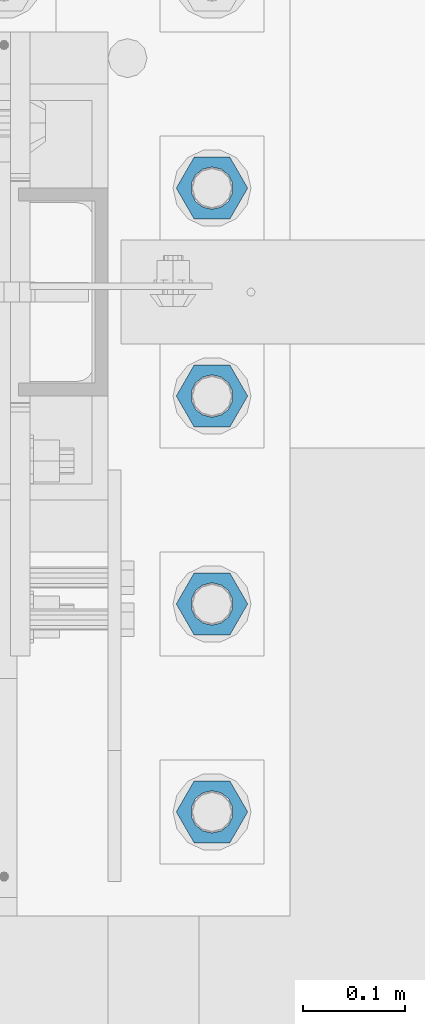
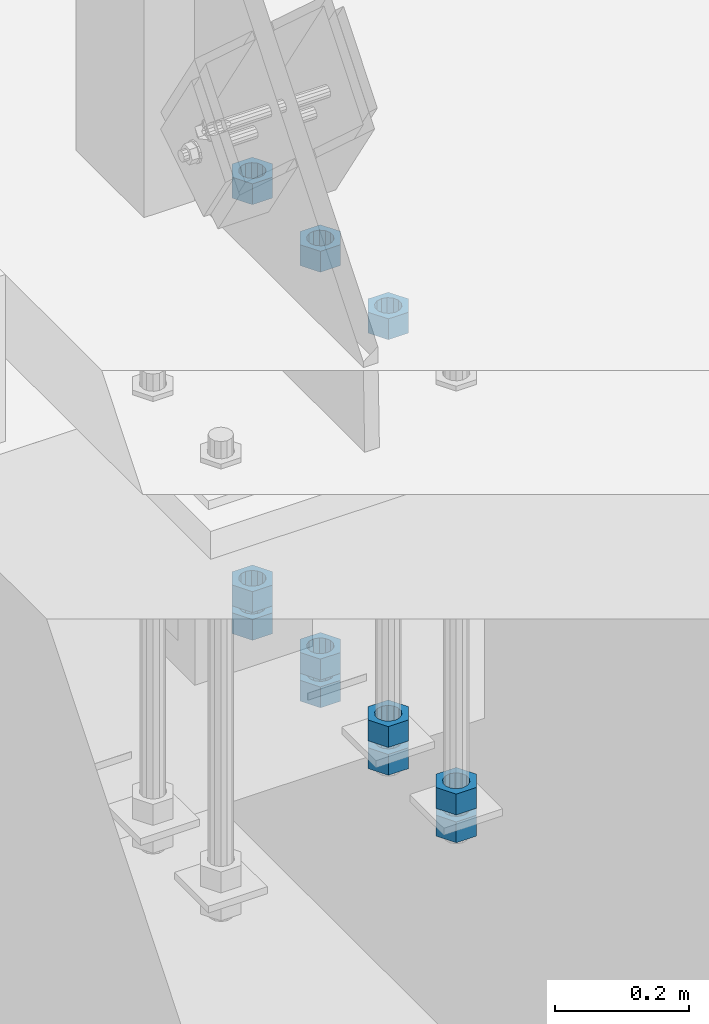
# One storey, part 989 of 1763: 11 columns, 1 element without a shape of its own.
"""IFC2X3 building model written with IfcOpenShell, lengths in millimetres."""

from ifc_helpers import new_model, si_unit, frame, origin_with_axes, place, context, subcontext, project, spatial, faceted_brep, material, type_object, element, aggregate, save


model = new_model("IFC2X3")

# Units and contexts
model_context = context("Model", 3, precision=1e-05, world=origin_with_axes())
body_context = subcontext(model_context, "Body", "Model", "MODEL_VIEW")
ifc_project = project(units=[si_unit("LENGTHUNIT", "METRE", prefix="MILLI"), si_unit("AREAUNIT", "SQUARE_METRE"), si_unit("VOLUMEUNIT", "CUBIC_METRE"), si_unit("MASSUNIT", "GRAM", prefix="KILO"), si_unit("TIMEUNIT", "SECOND"), si_unit("PLANEANGLEUNIT", "RADIAN"), si_unit("SOLIDANGLEUNIT", "STERADIAN"), si_unit("THERMODYNAMICTEMPERATUREUNIT", "DEGREE_CELSIUS"), si_unit("LUMINOUSINTENSITYUNIT", "LUMEN")], contexts=[model_context])

# Site, building, storey
site_placement = place(None, origin_with_axes())
site = spatial("IfcSite", under=ifc_project, at=site_placement, CompositionType="ELEMENT")
building_placement = place(site_placement, origin_with_axes())
building = spatial("IfcBuilding", under=site, at=building_placement, Name="Undefined", CompositionType="ELEMENT")
storey_placement = place(building_placement, origin_with_axes())
storey = spatial("IfcBuildingStorey", under=building, at=storey_placement, Name="Undefined", CompositionType="ELEMENT", Elevation=0.0)

# Assembly, columns
assembly_placement = place(storey_placement, origin_with_axes())
assembly = element("IfcElementAssembly", 1, at=assembly_placement, inside=storey, Name="TEMPLATE", AssemblyPlace="NOTDEFINED", PredefinedType="RIGID_FRAME")
ifc_material = material(Name="STEEL/A563")
column_type = type_object("IfcColumnType", Name="1-1/2_HEAVY_HEX_NUT", PredefinedType="NOTDEFINED")
column_1_placement = place(assembly_placement, frame((-87172.2372736984, 8026.40000000001, 4445.00000000001), z_axis=(0.0, 1.0, 0.0), x_axis=(0.0, 0.0, -1.0)))
column_1 = element("IfcColumn", 2, at=column_1_placement, type_object=column_type, material=ifc_material, Name="NUT", ObjectType="1-1/2_HEAVY_HEX_NUT", context=body_context, shape_type="Brep", body=[
    faceted_brep([(0.0, -34.9199981689453, 0.0), (0.0, -17.4599990844727, -30.25), (38.1000000000004, -17.4599990844727, -30.25), (38.1000000000004, -34.9199981689453, 0.0), (0.0, 17.4599990844727, -30.25), (38.1000000000004, 17.4599990844727, -30.25), (0.0, 34.9199981689453, 0.0), (38.1000000000004, 34.9199981689453, 0.0), (0.0, 17.4599990844727, 30.25), (38.1000000000004, 17.4599990844727, 30.25), (0.0, -17.4599990844727, 30.25), (38.1000000000004, -17.4599990844727, 30.25), (0.0, 0.0, 20.6399993896484), (0.0, 8.95536011056538, 18.5959968835978), (38.1000000000004, 8.95536011056538, 18.5959968835978), (38.1000000000004, 0.0, 20.6399993896484), (0.0, 16.1370013209453, 12.8688291298167), (38.1000000000004, 16.1370013209453, 12.8688291298167), (0.0, 20.1225115123816, 4.59283194104137), (38.1000000000004, 20.1225115123816, 4.59283194104137), (0.0, 20.1225115123816, -4.59283194104319), (38.1000000000004, 20.1225115123816, -4.59283194104319), (0.0, 16.1370013209453, -12.8688291298167), (38.1000000000004, 16.1370013209453, -12.8688291298167), (0.0, 8.95536011056538, -18.5959968835978), (38.1000000000004, 8.95536011056538, -18.5959968835978), (0.0, 0.0, -20.6399993896484), (38.1000000000004, 0.0, -20.6399993896484), (0.0, -8.95536011056538, -18.5959968835978), (38.1000000000004, -8.95536011056538, -18.5959968835978), (0.0, -16.1370013209453, -12.8688291298167), (38.1000000000004, -16.1370013209453, -12.8688291298167), (0.0, -20.1225115123816, -4.59283194104137), (38.1000000000004, -20.1225115123816, -4.59283194104137), (0.0, -20.1225115123816, 4.59283194104319), (38.1000000000004, -20.1225115123816, 4.59283194104319), (0.0, -16.1370013209453, 12.8688291298167), (38.1000000000004, -16.1370013209453, 12.8688291298167), (0.0, -8.95536011056538, 18.5959968835978), (38.1000000000004, -8.95536011056538, 18.5959968835978)], [[[0, 1, 2, 3]], [[1, 4, 5, 2]], [[4, 6, 7, 5]], [[6, 8, 9, 7]], [[8, 10, 11, 9]], [[10, 0, 3, 11]], [[12, 13, 14, 15]], [[13, 16, 17, 14]], [[16, 18, 19, 17]], [[18, 20, 21, 19]], [[20, 22, 23, 21]], [[22, 24, 25, 23]], [[24, 26, 27, 25]], [[26, 28, 29, 27]], [[28, 30, 31, 29]], [[30, 32, 33, 31]], [[32, 34, 35, 33]], [[34, 36, 37, 35]], [[36, 38, 39, 37]], [[38, 12, 15, 39]], [[5, 7, 9, 11, 3, 2], [17, 19, 21, 23, 25, 27, 29, 31, 33, 35, 37, 39, 15, 14]], [[10, 8, 6, 4, 1, 0], [38, 36, 34, 32, 30, 28, 26, 24, 22, 20, 18, 16, 13, 12]]]),
])
column_2_placement = place(assembly_placement, frame((-87172.2372736984, 8026.40000000001, 4394.20000000001), z_axis=(0.0, 1.0, 0.0), x_axis=(0.0, 0.0, -1.0)))
column_2 = element("IfcColumn", 3, at=column_2_placement, type_object=column_type, material=ifc_material, Name="NUT", ObjectType="1-1/2_HEAVY_HEX_NUT", context=body_context, shape_type="Brep", body=[
    faceted_brep([(0.0, -34.9199981689453, 0.0), (0.0, -17.4599990844727, -30.25), (38.1000000000004, -17.4599990844727, -30.25), (38.1000000000004, -34.9199981689453, 0.0), (0.0, 17.4599990844727, -30.25), (38.1000000000004, 17.4599990844727, -30.25), (0.0, 34.9199981689453, 0.0), (38.1000000000004, 34.9199981689453, 0.0), (0.0, 17.4599990844727, 30.25), (38.1000000000004, 17.4599990844727, 30.25), (0.0, -17.4599990844727, 30.25), (38.1000000000004, -17.4599990844727, 30.25), (0.0, 0.0, 20.6399993896484), (0.0, 8.95536011056538, 18.5959968835978), (38.1000000000004, 8.95536011056538, 18.5959968835978), (38.1000000000004, 0.0, 20.6399993896484), (0.0, 16.1370013209453, 12.8688291298167), (38.1000000000004, 16.1370013209453, 12.8688291298167), (0.0, 20.1225115123816, 4.59283194104137), (38.1000000000004, 20.1225115123816, 4.59283194104137), (0.0, 20.1225115123816, -4.59283194104319), (38.1000000000004, 20.1225115123816, -4.59283194104319), (0.0, 16.1370013209453, -12.8688291298167), (38.1000000000004, 16.1370013209453, -12.8688291298167), (0.0, 8.95536011056538, -18.5959968835978), (38.1000000000004, 8.95536011056538, -18.5959968835978), (0.0, 0.0, -20.6399993896484), (38.1000000000004, 0.0, -20.6399993896484), (0.0, -8.95536011056538, -18.5959968835978), (38.1000000000004, -8.95536011056538, -18.5959968835978), (0.0, -16.1370013209453, -12.8688291298167), (38.1000000000004, -16.1370013209453, -12.8688291298167), (0.0, -20.1225115123816, -4.59283194104137), (38.1000000000004, -20.1225115123816, -4.59283194104137), (0.0, -20.1225115123816, 4.59283194104319), (38.1000000000004, -20.1225115123816, 4.59283194104319), (0.0, -16.1370013209453, 12.8688291298167), (38.1000000000004, -16.1370013209453, 12.8688291298167), (0.0, -8.95536011056538, 18.5959968835978), (38.1000000000004, -8.95536011056538, 18.5959968835978)], [[[0, 1, 2, 3]], [[1, 4, 5, 2]], [[4, 6, 7, 5]], [[6, 8, 9, 7]], [[8, 10, 11, 9]], [[10, 0, 3, 11]], [[12, 13, 14, 15]], [[13, 16, 17, 14]], [[16, 18, 19, 17]], [[18, 20, 21, 19]], [[20, 22, 23, 21]], [[22, 24, 25, 23]], [[24, 26, 27, 25]], [[26, 28, 29, 27]], [[28, 30, 31, 29]], [[30, 32, 33, 31]], [[32, 34, 35, 33]], [[34, 36, 37, 35]], [[36, 38, 39, 37]], [[38, 12, 15, 39]], [[5, 7, 9, 11, 3, 2], [17, 19, 21, 23, 25, 27, 29, 31, 33, 35, 37, 39, 15, 14]], [[10, 8, 6, 4, 1, 0], [38, 36, 34, 32, 30, 28, 26, 24, 22, 20, 18, 16, 13, 12]]]),
])
column_3_placement = place(assembly_placement, frame((-87172.2372736984, 8229.60000000001, 5189.53750000001), z_axis=(0.0, 1.0, 0.0), x_axis=(0.0, 0.0, -1.0)))
column_3 = element("IfcColumn", 4, at=column_3_placement, type_object=column_type, material=ifc_material, Name="NUT", ObjectType="1-1/2_HEAVY_HEX_NUT", context=body_context, shape_type="Brep", body=[
    faceted_brep([(0.0, -34.9199981689453, 0.0), (0.0, -17.4599990844727, -30.25), (38.1000000000004, -17.4599990844727, -30.25), (38.1000000000004, -34.9199981689453, 0.0), (0.0, 17.4599990844727, -30.25), (38.1000000000004, 17.4599990844727, -30.25), (0.0, 34.9199981689453, 0.0), (38.1000000000004, 34.9199981689453, 0.0), (0.0, 17.4599990844727, 30.25), (38.1000000000004, 17.4599990844727, 30.25), (0.0, -17.4599990844727, 30.25), (38.1000000000004, -17.4599990844727, 30.25), (0.0, 0.0, 20.6399993896484), (0.0, 8.95536011056538, 18.5959968835978), (38.1000000000004, 8.95536011056538, 18.5959968835978), (38.1000000000004, 0.0, 20.6399993896484), (0.0, 16.1370013209453, 12.8688291298167), (38.1000000000004, 16.1370013209453, 12.8688291298167), (0.0, 20.1225115123816, 4.59283194104137), (38.1000000000004, 20.1225115123816, 4.59283194104137), (0.0, 20.1225115123816, -4.59283194104319), (38.1000000000004, 20.1225115123816, -4.59283194104319), (0.0, 16.1370013209453, -12.8688291298167), (38.1000000000004, 16.1370013209453, -12.8688291298167), (0.0, 8.95536011056538, -18.5959968835978), (38.1000000000004, 8.95536011056538, -18.5959968835978), (0.0, 0.0, -20.6399993896484), (38.1000000000004, 0.0, -20.6399993896484), (0.0, -8.95536011056538, -18.5959968835978), (38.1000000000004, -8.95536011056538, -18.5959968835978), (0.0, -16.1370013209453, -12.8688291298167), (38.1000000000004, -16.1370013209453, -12.8688291298167), (0.0, -20.1225115123816, -4.59283194104137), (38.1000000000004, -20.1225115123816, -4.59283194104137), (0.0, -20.1225115123816, 4.59283194104319), (38.1000000000004, -20.1225115123816, 4.59283194104319), (0.0, -16.1370013209453, 12.8688291298167), (38.1000000000004, -16.1370013209453, 12.8688291298167), (0.0, -8.95536011056538, 18.5959968835978), (38.1000000000004, -8.95536011056538, 18.5959968835978)], [[[0, 1, 2, 3]], [[1, 4, 5, 2]], [[4, 6, 7, 5]], [[6, 8, 9, 7]], [[8, 10, 11, 9]], [[10, 0, 3, 11]], [[12, 13, 14, 15]], [[13, 16, 17, 14]], [[16, 18, 19, 17]], [[18, 20, 21, 19]], [[20, 22, 23, 21]], [[22, 24, 25, 23]], [[24, 26, 27, 25]], [[26, 28, 29, 27]], [[28, 30, 31, 29]], [[30, 32, 33, 31]], [[32, 34, 35, 33]], [[34, 36, 37, 35]], [[36, 38, 39, 37]], [[38, 12, 15, 39]], [[5, 7, 9, 11, 3, 2], [17, 19, 21, 23, 25, 27, 29, 31, 33, 35, 37, 39, 15, 14]], [[10, 8, 6, 4, 1, 0], [38, 36, 34, 32, 30, 28, 26, 24, 22, 20, 18, 16, 13, 12]]]),
])
column_4_placement = place(assembly_placement, frame((-87172.2372736984, 8229.60000000001, 4445.00000000001), z_axis=(0.0, 1.0, 0.0), x_axis=(0.0, 0.0, -1.0)))
column_4 = element("IfcColumn", 5, at=column_4_placement, type_object=column_type, material=ifc_material, Name="NUT", ObjectType="1-1/2_HEAVY_HEX_NUT", context=body_context, shape_type="Brep", body=[
    faceted_brep([(0.0, -34.9199981689453, 0.0), (0.0, -17.4599990844727, -30.25), (38.1000000000004, -17.4599990844727, -30.25), (38.1000000000004, -34.9199981689453, 0.0), (0.0, 17.4599990844727, -30.25), (38.1000000000004, 17.4599990844727, -30.25), (0.0, 34.9199981689453, 0.0), (38.1000000000004, 34.9199981689453, 0.0), (0.0, 17.4599990844727, 30.25), (38.1000000000004, 17.4599990844727, 30.25), (0.0, -17.4599990844727, 30.25), (38.1000000000004, -17.4599990844727, 30.25), (0.0, 0.0, 20.6399993896484), (0.0, 8.95536011056538, 18.5959968835978), (38.1000000000004, 8.95536011056538, 18.5959968835978), (38.1000000000004, 0.0, 20.6399993896484), (0.0, 16.1370013209453, 12.8688291298167), (38.1000000000004, 16.1370013209453, 12.8688291298167), (0.0, 20.1225115123816, 4.59283194104137), (38.1000000000004, 20.1225115123816, 4.59283194104137), (0.0, 20.1225115123816, -4.59283194104319), (38.1000000000004, 20.1225115123816, -4.59283194104319), (0.0, 16.1370013209453, -12.8688291298167), (38.1000000000004, 16.1370013209453, -12.8688291298167), (0.0, 8.95536011056538, -18.5959968835978), (38.1000000000004, 8.95536011056538, -18.5959968835978), (0.0, 0.0, -20.6399993896484), (38.1000000000004, 0.0, -20.6399993896484), (0.0, -8.95536011056538, -18.5959968835978), (38.1000000000004, -8.95536011056538, -18.5959968835978), (0.0, -16.1370013209453, -12.8688291298167), (38.1000000000004, -16.1370013209453, -12.8688291298167), (0.0, -20.1225115123816, -4.59283194104137), (38.1000000000004, -20.1225115123816, -4.59283194104137), (0.0, -20.1225115123816, 4.59283194104319), (38.1000000000004, -20.1225115123816, 4.59283194104319), (0.0, -16.1370013209453, 12.8688291298167), (38.1000000000004, -16.1370013209453, 12.8688291298167), (0.0, -8.95536011056538, 18.5959968835978), (38.1000000000004, -8.95536011056538, 18.5959968835978)], [[[0, 1, 2, 3]], [[1, 4, 5, 2]], [[4, 6, 7, 5]], [[6, 8, 9, 7]], [[8, 10, 11, 9]], [[10, 0, 3, 11]], [[12, 13, 14, 15]], [[13, 16, 17, 14]], [[16, 18, 19, 17]], [[18, 20, 21, 19]], [[20, 22, 23, 21]], [[22, 24, 25, 23]], [[24, 26, 27, 25]], [[26, 28, 29, 27]], [[28, 30, 31, 29]], [[30, 32, 33, 31]], [[32, 34, 35, 33]], [[34, 36, 37, 35]], [[36, 38, 39, 37]], [[38, 12, 15, 39]], [[5, 7, 9, 11, 3, 2], [17, 19, 21, 23, 25, 27, 29, 31, 33, 35, 37, 39, 15, 14]], [[10, 8, 6, 4, 1, 0], [38, 36, 34, 32, 30, 28, 26, 24, 22, 20, 18, 16, 13, 12]]]),
])
column_5_placement = place(assembly_placement, frame((-87172.2372736984, 8229.60000000001, 4394.20000000001), z_axis=(0.0, 1.0, 0.0), x_axis=(0.0, 0.0, -1.0)))
column_5 = element("IfcColumn", 6, at=column_5_placement, type_object=column_type, material=ifc_material, Name="NUT", ObjectType="1-1/2_HEAVY_HEX_NUT", context=body_context, shape_type="Brep", body=[
    faceted_brep([(0.0, -34.9199981689453, 0.0), (0.0, -17.4599990844727, -30.25), (38.1000000000004, -17.4599990844727, -30.25), (38.1000000000004, -34.9199981689453, 0.0), (0.0, 17.4599990844727, -30.25), (38.1000000000004, 17.4599990844727, -30.25), (0.0, 34.9199981689453, 0.0), (38.1000000000004, 34.9199981689453, 0.0), (0.0, 17.4599990844727, 30.25), (38.1000000000004, 17.4599990844727, 30.25), (0.0, -17.4599990844727, 30.25), (38.1000000000004, -17.4599990844727, 30.25), (0.0, 0.0, 20.6399993896484), (0.0, 8.95536011056538, 18.5959968835978), (38.1000000000004, 8.95536011056538, 18.5959968835978), (38.1000000000004, 0.0, 20.6399993896484), (0.0, 16.1370013209453, 12.8688291298167), (38.1000000000004, 16.1370013209453, 12.8688291298167), (0.0, 20.1225115123816, 4.59283194104137), (38.1000000000004, 20.1225115123816, 4.59283194104137), (0.0, 20.1225115123816, -4.59283194104319), (38.1000000000004, 20.1225115123816, -4.59283194104319), (0.0, 16.1370013209453, -12.8688291298167), (38.1000000000004, 16.1370013209453, -12.8688291298167), (0.0, 8.95536011056538, -18.5959968835978), (38.1000000000004, 8.95536011056538, -18.5959968835978), (0.0, 0.0, -20.6399993896484), (38.1000000000004, 0.0, -20.6399993896484), (0.0, -8.95536011056538, -18.5959968835978), (38.1000000000004, -8.95536011056538, -18.5959968835978), (0.0, -16.1370013209453, -12.8688291298167), (38.1000000000004, -16.1370013209453, -12.8688291298167), (0.0, -20.1225115123816, -4.59283194104137), (38.1000000000004, -20.1225115123816, -4.59283194104137), (0.0, -20.1225115123816, 4.59283194104319), (38.1000000000004, -20.1225115123816, 4.59283194104319), (0.0, -16.1370013209453, 12.8688291298167), (38.1000000000004, -16.1370013209453, 12.8688291298167), (0.0, -8.95536011056538, 18.5959968835978), (38.1000000000004, -8.95536011056538, 18.5959968835978)], [[[0, 1, 2, 3]], [[1, 4, 5, 2]], [[4, 6, 7, 5]], [[6, 8, 9, 7]], [[8, 10, 11, 9]], [[10, 0, 3, 11]], [[12, 13, 14, 15]], [[13, 16, 17, 14]], [[16, 18, 19, 17]], [[18, 20, 21, 19]], [[20, 22, 23, 21]], [[22, 24, 25, 23]], [[24, 26, 27, 25]], [[26, 28, 29, 27]], [[28, 30, 31, 29]], [[30, 32, 33, 31]], [[32, 34, 35, 33]], [[34, 36, 37, 35]], [[36, 38, 39, 37]], [[38, 12, 15, 39]], [[5, 7, 9, 11, 3, 2], [17, 19, 21, 23, 25, 27, 29, 31, 33, 35, 37, 39, 15, 14]], [[10, 8, 6, 4, 1, 0], [38, 36, 34, 32, 30, 28, 26, 24, 22, 20, 18, 16, 13, 12]]]),
])
column_6_placement = place(assembly_placement, frame((-87172.2372736984, 8432.80000000001, 5189.53750000001), z_axis=(0.0, 1.0, 0.0), x_axis=(0.0, 0.0, -1.0)))
column_6 = element("IfcColumn", 7, at=column_6_placement, type_object=column_type, material=ifc_material, Name="NUT", ObjectType="1-1/2_HEAVY_HEX_NUT", context=body_context, shape_type="Brep", body=[
    faceted_brep([(0.0, -34.9199981689453, 0.0), (0.0, -17.4599990844727, -30.25), (38.1000000000004, -17.4599990844727, -30.25), (38.1000000000004, -34.9199981689453, 0.0), (0.0, 17.4599990844727, -30.25), (38.1000000000004, 17.4599990844727, -30.25), (0.0, 34.9199981689453, 0.0), (38.1000000000004, 34.9199981689453, 0.0), (0.0, 17.4599990844727, 30.25), (38.1000000000004, 17.4599990844727, 30.25), (0.0, -17.4599990844727, 30.25), (38.1000000000004, -17.4599990844727, 30.25), (0.0, 0.0, 20.6399993896484), (0.0, 8.95536011056538, 18.5959968835978), (38.1000000000004, 8.95536011056538, 18.5959968835978), (38.1000000000004, 0.0, 20.6399993896484), (0.0, 16.1370013209453, 12.8688291298167), (38.1000000000004, 16.1370013209453, 12.8688291298167), (0.0, 20.1225115123816, 4.59283194104137), (38.1000000000004, 20.1225115123816, 4.59283194104137), (0.0, 20.1225115123816, -4.59283194104319), (38.1000000000004, 20.1225115123816, -4.59283194104319), (0.0, 16.1370013209453, -12.8688291298167), (38.1000000000004, 16.1370013209453, -12.8688291298167), (0.0, 8.95536011056538, -18.5959968835978), (38.1000000000004, 8.95536011056538, -18.5959968835978), (0.0, 0.0, -20.6399993896484), (38.1000000000004, 0.0, -20.6399993896484), (0.0, -8.95536011056538, -18.5959968835978), (38.1000000000004, -8.95536011056538, -18.5959968835978), (0.0, -16.1370013209453, -12.8688291298167), (38.1000000000004, -16.1370013209453, -12.8688291298167), (0.0, -20.1225115123816, -4.59283194104137), (38.1000000000004, -20.1225115123816, -4.59283194104137), (0.0, -20.1225115123816, 4.59283194104319), (38.1000000000004, -20.1225115123816, 4.59283194104319), (0.0, -16.1370013209453, 12.8688291298167), (38.1000000000004, -16.1370013209453, 12.8688291298167), (0.0, -8.95536011056538, 18.5959968835978), (38.1000000000004, -8.95536011056538, 18.5959968835978)], [[[0, 1, 2, 3]], [[1, 4, 5, 2]], [[4, 6, 7, 5]], [[6, 8, 9, 7]], [[8, 10, 11, 9]], [[10, 0, 3, 11]], [[12, 13, 14, 15]], [[13, 16, 17, 14]], [[16, 18, 19, 17]], [[18, 20, 21, 19]], [[20, 22, 23, 21]], [[22, 24, 25, 23]], [[24, 26, 27, 25]], [[26, 28, 29, 27]], [[28, 30, 31, 29]], [[30, 32, 33, 31]], [[32, 34, 35, 33]], [[34, 36, 37, 35]], [[36, 38, 39, 37]], [[38, 12, 15, 39]], [[5, 7, 9, 11, 3, 2], [17, 19, 21, 23, 25, 27, 29, 31, 33, 35, 37, 39, 15, 14]], [[10, 8, 6, 4, 1, 0], [38, 36, 34, 32, 30, 28, 26, 24, 22, 20, 18, 16, 13, 12]]]),
])
column_7_placement = place(assembly_placement, frame((-87172.2372736984, 8432.80000000001, 4445.00000000001), z_axis=(0.0, 1.0, 0.0), x_axis=(0.0, 0.0, -1.0)))
column_7 = element("IfcColumn", 8, at=column_7_placement, type_object=column_type, material=ifc_material, Name="NUT", ObjectType="1-1/2_HEAVY_HEX_NUT", context=body_context, shape_type="Brep", body=[
    faceted_brep([(0.0, -34.9199981689453, 0.0), (0.0, -17.4599990844727, -30.25), (38.1000000000004, -17.4599990844727, -30.25), (38.1000000000004, -34.9199981689453, 0.0), (0.0, 17.4599990844727, -30.25), (38.1000000000004, 17.4599990844727, -30.25), (0.0, 34.9199981689453, 0.0), (38.1000000000004, 34.9199981689453, 0.0), (0.0, 17.4599990844727, 30.25), (38.1000000000004, 17.4599990844727, 30.25), (0.0, -17.4599990844727, 30.25), (38.1000000000004, -17.4599990844727, 30.25), (0.0, 0.0, 20.6399993896484), (0.0, 8.95536011056538, 18.5959968835978), (38.1000000000004, 8.95536011056538, 18.5959968835978), (38.1000000000004, 0.0, 20.6399993896484), (0.0, 16.1370013209453, 12.8688291298167), (38.1000000000004, 16.1370013209453, 12.8688291298167), (0.0, 20.1225115123816, 4.59283194104137), (38.1000000000004, 20.1225115123816, 4.59283194104137), (0.0, 20.1225115123816, -4.59283194104319), (38.1000000000004, 20.1225115123816, -4.59283194104319), (0.0, 16.1370013209453, -12.8688291298167), (38.1000000000004, 16.1370013209453, -12.8688291298167), (0.0, 8.95536011056538, -18.5959968835978), (38.1000000000004, 8.95536011056538, -18.5959968835978), (0.0, 0.0, -20.6399993896484), (38.1000000000004, 0.0, -20.6399993896484), (0.0, -8.95536011056538, -18.5959968835978), (38.1000000000004, -8.95536011056538, -18.5959968835978), (0.0, -16.1370013209453, -12.8688291298167), (38.1000000000004, -16.1370013209453, -12.8688291298167), (0.0, -20.1225115123816, -4.59283194104137), (38.1000000000004, -20.1225115123816, -4.59283194104137), (0.0, -20.1225115123816, 4.59283194104319), (38.1000000000004, -20.1225115123816, 4.59283194104319), (0.0, -16.1370013209453, 12.8688291298167), (38.1000000000004, -16.1370013209453, 12.8688291298167), (0.0, -8.95536011056538, 18.5959968835978), (38.1000000000004, -8.95536011056538, 18.5959968835978)], [[[0, 1, 2, 3]], [[1, 4, 5, 2]], [[4, 6, 7, 5]], [[6, 8, 9, 7]], [[8, 10, 11, 9]], [[10, 0, 3, 11]], [[12, 13, 14, 15]], [[13, 16, 17, 14]], [[16, 18, 19, 17]], [[18, 20, 21, 19]], [[20, 22, 23, 21]], [[22, 24, 25, 23]], [[24, 26, 27, 25]], [[26, 28, 29, 27]], [[28, 30, 31, 29]], [[30, 32, 33, 31]], [[32, 34, 35, 33]], [[34, 36, 37, 35]], [[36, 38, 39, 37]], [[38, 12, 15, 39]], [[5, 7, 9, 11, 3, 2], [17, 19, 21, 23, 25, 27, 29, 31, 33, 35, 37, 39, 15, 14]], [[10, 8, 6, 4, 1, 0], [38, 36, 34, 32, 30, 28, 26, 24, 22, 20, 18, 16, 13, 12]]]),
])
column_8_placement = place(assembly_placement, frame((-87172.2372736984, 8432.80000000001, 4394.20000000001), z_axis=(0.0, 1.0, 0.0), x_axis=(0.0, 0.0, -1.0)))
column_8 = element("IfcColumn", 9, at=column_8_placement, type_object=column_type, material=ifc_material, Name="NUT", ObjectType="1-1/2_HEAVY_HEX_NUT", context=body_context, shape_type="Brep", body=[
    faceted_brep([(0.0, -34.9199981689453, 0.0), (0.0, -17.4599990844727, -30.25), (38.1000000000004, -17.4599990844727, -30.25), (38.1000000000004, -34.9199981689453, 0.0), (0.0, 17.4599990844727, -30.25), (38.1000000000004, 17.4599990844727, -30.25), (0.0, 34.9199981689453, 0.0), (38.1000000000004, 34.9199981689453, 0.0), (0.0, 17.4599990844727, 30.25), (38.1000000000004, 17.4599990844727, 30.25), (0.0, -17.4599990844727, 30.25), (38.1000000000004, -17.4599990844727, 30.25), (0.0, 0.0, 20.6399993896484), (0.0, 8.95536011056538, 18.5959968835978), (38.1000000000004, 8.95536011056538, 18.5959968835978), (38.1000000000004, 0.0, 20.6399993896484), (0.0, 16.1370013209453, 12.8688291298167), (38.1000000000004, 16.1370013209453, 12.8688291298167), (0.0, 20.1225115123816, 4.59283194104137), (38.1000000000004, 20.1225115123816, 4.59283194104137), (0.0, 20.1225115123816, -4.59283194104319), (38.1000000000004, 20.1225115123816, -4.59283194104319), (0.0, 16.1370013209453, -12.8688291298167), (38.1000000000004, 16.1370013209453, -12.8688291298167), (0.0, 8.95536011056538, -18.5959968835978), (38.1000000000004, 8.95536011056538, -18.5959968835978), (0.0, 0.0, -20.6399993896484), (38.1000000000004, 0.0, -20.6399993896484), (0.0, -8.95536011056538, -18.5959968835978), (38.1000000000004, -8.95536011056538, -18.5959968835978), (0.0, -16.1370013209453, -12.8688291298167), (38.1000000000004, -16.1370013209453, -12.8688291298167), (0.0, -20.1225115123816, -4.59283194104137), (38.1000000000004, -20.1225115123816, -4.59283194104137), (0.0, -20.1225115123816, 4.59283194104319), (38.1000000000004, -20.1225115123816, 4.59283194104319), (0.0, -16.1370013209453, 12.8688291298167), (38.1000000000004, -16.1370013209453, 12.8688291298167), (0.0, -8.95536011056538, 18.5959968835978), (38.1000000000004, -8.95536011056538, 18.5959968835978)], [[[0, 1, 2, 3]], [[1, 4, 5, 2]], [[4, 6, 7, 5]], [[6, 8, 9, 7]], [[8, 10, 11, 9]], [[10, 0, 3, 11]], [[12, 13, 14, 15]], [[13, 16, 17, 14]], [[16, 18, 19, 17]], [[18, 20, 21, 19]], [[20, 22, 23, 21]], [[22, 24, 25, 23]], [[24, 26, 27, 25]], [[26, 28, 29, 27]], [[28, 30, 31, 29]], [[30, 32, 33, 31]], [[32, 34, 35, 33]], [[34, 36, 37, 35]], [[36, 38, 39, 37]], [[38, 12, 15, 39]], [[5, 7, 9, 11, 3, 2], [17, 19, 21, 23, 25, 27, 29, 31, 33, 35, 37, 39, 15, 14]], [[10, 8, 6, 4, 1, 0], [38, 36, 34, 32, 30, 28, 26, 24, 22, 20, 18, 16, 13, 12]]]),
])
column_9_placement = place(assembly_placement, frame((-87172.2372736984, 8636.00000000001, 5189.53750000001), z_axis=(0.0, 1.0, 0.0), x_axis=(0.0, 0.0, -1.0)))
column_9 = element("IfcColumn", 10, at=column_9_placement, type_object=column_type, material=ifc_material, Name="NUT", ObjectType="1-1/2_HEAVY_HEX_NUT", context=body_context, shape_type="Brep", body=[
    faceted_brep([(0.0, -34.9199981689453, 0.0), (0.0, -17.4599990844727, -30.25), (38.1000000000004, -17.4599990844727, -30.25), (38.1000000000004, -34.9199981689453, 0.0), (0.0, 17.4599990844727, -30.25), (38.1000000000004, 17.4599990844727, -30.25), (0.0, 34.9199981689453, 0.0), (38.1000000000004, 34.9199981689453, 0.0), (0.0, 17.4599990844727, 30.25), (38.1000000000004, 17.4599990844727, 30.25), (0.0, -17.4599990844727, 30.25), (38.1000000000004, -17.4599990844727, 30.25), (0.0, 0.0, 20.6399993896484), (0.0, 8.95536011056538, 18.5959968835978), (38.1000000000004, 8.95536011056538, 18.5959968835978), (38.1000000000004, 0.0, 20.6399993896484), (0.0, 16.1370013209453, 12.8688291298167), (38.1000000000004, 16.1370013209453, 12.8688291298167), (0.0, 20.1225115123816, 4.59283194104137), (38.1000000000004, 20.1225115123816, 4.59283194104137), (0.0, 20.1225115123816, -4.59283194104319), (38.1000000000004, 20.1225115123816, -4.59283194104319), (0.0, 16.1370013209453, -12.8688291298167), (38.1000000000004, 16.1370013209453, -12.8688291298167), (0.0, 8.95536011056538, -18.5959968835978), (38.1000000000004, 8.95536011056538, -18.5959968835978), (0.0, 0.0, -20.6399993896484), (38.1000000000004, 0.0, -20.6399993896484), (0.0, -8.95536011056538, -18.5959968835978), (38.1000000000004, -8.95536011056538, -18.5959968835978), (0.0, -16.1370013209453, -12.8688291298167), (38.1000000000004, -16.1370013209453, -12.8688291298167), (0.0, -20.1225115123816, -4.59283194104137), (38.1000000000004, -20.1225115123816, -4.59283194104137), (0.0, -20.1225115123816, 4.59283194104319), (38.1000000000004, -20.1225115123816, 4.59283194104319), (0.0, -16.1370013209453, 12.8688291298167), (38.1000000000004, -16.1370013209453, 12.8688291298167), (0.0, -8.95536011056538, 18.5959968835978), (38.1000000000004, -8.95536011056538, 18.5959968835978)], [[[0, 1, 2, 3]], [[1, 4, 5, 2]], [[4, 6, 7, 5]], [[6, 8, 9, 7]], [[8, 10, 11, 9]], [[10, 0, 3, 11]], [[12, 13, 14, 15]], [[13, 16, 17, 14]], [[16, 18, 19, 17]], [[18, 20, 21, 19]], [[20, 22, 23, 21]], [[22, 24, 25, 23]], [[24, 26, 27, 25]], [[26, 28, 29, 27]], [[28, 30, 31, 29]], [[30, 32, 33, 31]], [[32, 34, 35, 33]], [[34, 36, 37, 35]], [[36, 38, 39, 37]], [[38, 12, 15, 39]], [[5, 7, 9, 11, 3, 2], [17, 19, 21, 23, 25, 27, 29, 31, 33, 35, 37, 39, 15, 14]], [[10, 8, 6, 4, 1, 0], [38, 36, 34, 32, 30, 28, 26, 24, 22, 20, 18, 16, 13, 12]]]),
])
column_10_placement = place(assembly_placement, frame((-87172.2372736984, 8636.00000000001, 4445.00000000001), z_axis=(0.0, 1.0, 0.0), x_axis=(0.0, 0.0, -1.0)))
column_10 = element("IfcColumn", 11, at=column_10_placement, type_object=column_type, material=ifc_material, Name="NUT", ObjectType="1-1/2_HEAVY_HEX_NUT", context=body_context, shape_type="Brep", body=[
    faceted_brep([(0.0, -34.9199981689453, 0.0), (0.0, -17.4599990844727, -30.25), (38.1000000000004, -17.4599990844727, -30.25), (38.1000000000004, -34.9199981689453, 0.0), (0.0, 17.4599990844727, -30.25), (38.1000000000004, 17.4599990844727, -30.25), (0.0, 34.9199981689453, 0.0), (38.1000000000004, 34.9199981689453, 0.0), (0.0, 17.4599990844727, 30.25), (38.1000000000004, 17.4599990844727, 30.25), (0.0, -17.4599990844727, 30.25), (38.1000000000004, -17.4599990844727, 30.25), (0.0, 0.0, 20.6399993896484), (0.0, 8.95536011056538, 18.5959968835978), (38.1000000000004, 8.95536011056538, 18.5959968835978), (38.1000000000004, 0.0, 20.6399993896484), (0.0, 16.1370013209453, 12.8688291298167), (38.1000000000004, 16.1370013209453, 12.8688291298167), (0.0, 20.1225115123816, 4.59283194104137), (38.1000000000004, 20.1225115123816, 4.59283194104137), (0.0, 20.1225115123816, -4.59283194104319), (38.1000000000004, 20.1225115123816, -4.59283194104319), (0.0, 16.1370013209453, -12.8688291298167), (38.1000000000004, 16.1370013209453, -12.8688291298167), (0.0, 8.95536011056538, -18.5959968835978), (38.1000000000004, 8.95536011056538, -18.5959968835978), (0.0, 0.0, -20.6399993896484), (38.1000000000004, 0.0, -20.6399993896484), (0.0, -8.95536011056538, -18.5959968835978), (38.1000000000004, -8.95536011056538, -18.5959968835978), (0.0, -16.1370013209453, -12.8688291298167), (38.1000000000004, -16.1370013209453, -12.8688291298167), (0.0, -20.1225115123816, -4.59283194104137), (38.1000000000004, -20.1225115123816, -4.59283194104137), (0.0, -20.1225115123816, 4.59283194104319), (38.1000000000004, -20.1225115123816, 4.59283194104319), (0.0, -16.1370013209453, 12.8688291298167), (38.1000000000004, -16.1370013209453, 12.8688291298167), (0.0, -8.95536011056538, 18.5959968835978), (38.1000000000004, -8.95536011056538, 18.5959968835978)], [[[0, 1, 2, 3]], [[1, 4, 5, 2]], [[4, 6, 7, 5]], [[6, 8, 9, 7]], [[8, 10, 11, 9]], [[10, 0, 3, 11]], [[12, 13, 14, 15]], [[13, 16, 17, 14]], [[16, 18, 19, 17]], [[18, 20, 21, 19]], [[20, 22, 23, 21]], [[22, 24, 25, 23]], [[24, 26, 27, 25]], [[26, 28, 29, 27]], [[28, 30, 31, 29]], [[30, 32, 33, 31]], [[32, 34, 35, 33]], [[34, 36, 37, 35]], [[36, 38, 39, 37]], [[38, 12, 15, 39]], [[5, 7, 9, 11, 3, 2], [17, 19, 21, 23, 25, 27, 29, 31, 33, 35, 37, 39, 15, 14]], [[10, 8, 6, 4, 1, 0], [38, 36, 34, 32, 30, 28, 26, 24, 22, 20, 18, 16, 13, 12]]]),
])
column_11_placement = place(assembly_placement, frame((-87172.2372736984, 8636.00000000001, 4394.20000000001), z_axis=(0.0, 1.0, 0.0), x_axis=(0.0, 0.0, -1.0)))
column_11 = element("IfcColumn", 12, at=column_11_placement, type_object=column_type, material=ifc_material, Name="NUT", ObjectType="1-1/2_HEAVY_HEX_NUT", context=body_context, shape_type="Brep", body=[
    faceted_brep([(0.0, -34.9199981689453, 0.0), (0.0, -17.4599990844727, -30.25), (38.1000000000004, -17.4599990844727, -30.25), (38.1000000000004, -34.9199981689453, 0.0), (0.0, 17.4599990844727, -30.25), (38.1000000000004, 17.4599990844727, -30.25), (0.0, 34.9199981689453, 0.0), (38.1000000000004, 34.9199981689453, 0.0), (0.0, 17.4599990844727, 30.25), (38.1000000000004, 17.4599990844727, 30.25), (0.0, -17.4599990844727, 30.25), (38.1000000000004, -17.4599990844727, 30.25), (0.0, 0.0, 20.6399993896484), (0.0, 8.95536011056538, 18.5959968835978), (38.1000000000004, 8.95536011056538, 18.5959968835978), (38.1000000000004, 0.0, 20.6399993896484), (0.0, 16.1370013209453, 12.8688291298167), (38.1000000000004, 16.1370013209453, 12.8688291298167), (0.0, 20.1225115123816, 4.59283194104137), (38.1000000000004, 20.1225115123816, 4.59283194104137), (0.0, 20.1225115123816, -4.59283194104319), (38.1000000000004, 20.1225115123816, -4.59283194104319), (0.0, 16.1370013209453, -12.8688291298167), (38.1000000000004, 16.1370013209453, -12.8688291298167), (0.0, 8.95536011056538, -18.5959968835978), (38.1000000000004, 8.95536011056538, -18.5959968835978), (0.0, 0.0, -20.6399993896484), (38.1000000000004, 0.0, -20.6399993896484), (0.0, -8.95536011056538, -18.5959968835978), (38.1000000000004, -8.95536011056538, -18.5959968835978), (0.0, -16.1370013209453, -12.8688291298167), (38.1000000000004, -16.1370013209453, -12.8688291298167), (0.0, -20.1225115123816, -4.59283194104137), (38.1000000000004, -20.1225115123816, -4.59283194104137), (0.0, -20.1225115123816, 4.59283194104319), (38.1000000000004, -20.1225115123816, 4.59283194104319), (0.0, -16.1370013209453, 12.8688291298167), (38.1000000000004, -16.1370013209453, 12.8688291298167), (0.0, -8.95536011056538, 18.5959968835978), (38.1000000000004, -8.95536011056538, 18.5959968835978)], [[[0, 1, 2, 3]], [[1, 4, 5, 2]], [[4, 6, 7, 5]], [[6, 8, 9, 7]], [[8, 10, 11, 9]], [[10, 0, 3, 11]], [[12, 13, 14, 15]], [[13, 16, 17, 14]], [[16, 18, 19, 17]], [[18, 20, 21, 19]], [[20, 22, 23, 21]], [[22, 24, 25, 23]], [[24, 26, 27, 25]], [[26, 28, 29, 27]], [[28, 30, 31, 29]], [[30, 32, 33, 31]], [[32, 34, 35, 33]], [[34, 36, 37, 35]], [[36, 38, 39, 37]], [[38, 12, 15, 39]], [[5, 7, 9, 11, 3, 2], [17, 19, 21, 23, 25, 27, 29, 31, 33, 35, 37, 39, 15, 14]], [[10, 8, 6, 4, 1, 0], [38, 36, 34, 32, 30, 28, 26, 24, 22, 20, 18, 16, 13, 12]]]),
])
aggregate(assembly, [column_1, column_2, column_3, column_4, column_5, column_6, column_7, column_8, column_9, column_10, column_11])

save(model, "model.ifc")
